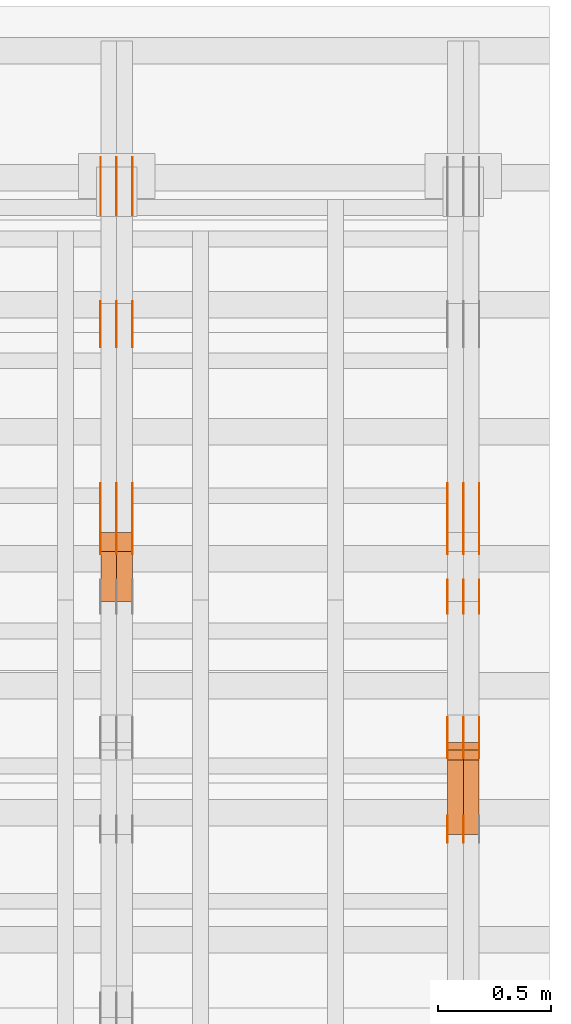
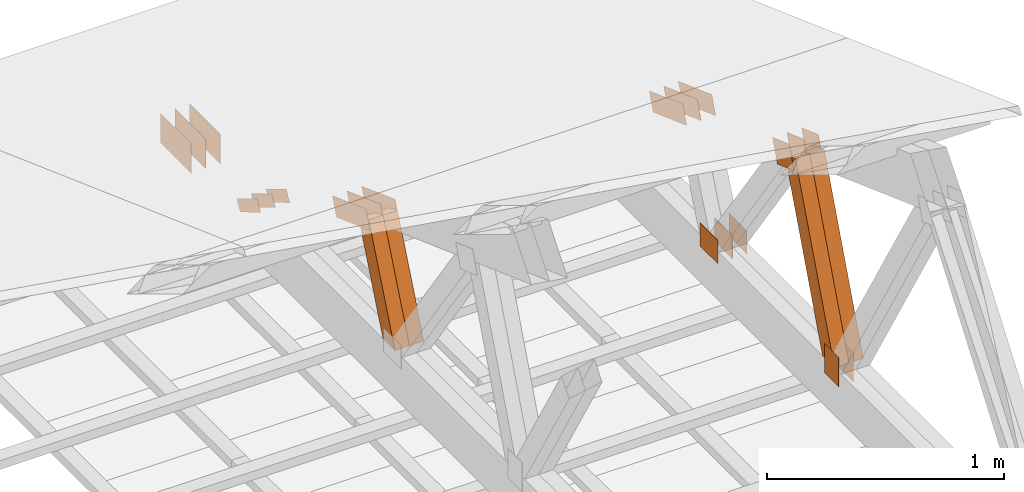
# One storey, part 177 of 189: 30 proxies.
"""IFC2X3 building model written with IfcOpenShell, lengths in millimetres."""

from ifc_helpers import new_model, entity, si_unit, converted_unit, derived_unit, direction, frame, frame_2d, origin, origin_2d_with_axis, place, context, subcontext, project, spatial, polyline, rectangle, outline, extrude, source, transform, mapped, material, type_object, type_shapes, element, save


model = new_model("IFC2X3")

# Units and contexts
model_context = context("Model", 3, precision=0.01, world=origin(), true_north=direction((6.12303176911189e-17, 1.0)))
body_context = subcontext(model_context, "Body", "Model", "MODEL_VIEW")
ifc_project = project(units=[si_unit("LENGTHUNIT", "METRE", prefix="MILLI"), si_unit("AREAUNIT", "SQUARE_METRE"), si_unit("VOLUMEUNIT", "CUBIC_METRE"), converted_unit("PLANEANGLEUNIT", "DEGREE", entity("IfcRatioMeasure", 0.0174532925199433), si_unit("PLANEANGLEUNIT", "RADIAN"), dimensions=[0, 0, 0, 0, 0, 0, 0]), si_unit("MASSUNIT", "GRAM", prefix="KILO"), derived_unit("MASSDENSITYUNIT", [(si_unit("MASSUNIT", "GRAM", prefix="KILO"), 1), (si_unit("LENGTHUNIT", "METRE"), -3)]), si_unit("TIMEUNIT", "SECOND"), si_unit("FREQUENCYUNIT", "HERTZ"), si_unit("THERMODYNAMICTEMPERATUREUNIT", "DEGREE_CELSIUS"), derived_unit("THERMALTRANSMITTANCEUNIT", [(si_unit("MASSUNIT", "GRAM", prefix="KILO"), 1), (si_unit("THERMODYNAMICTEMPERATUREUNIT", "KELVIN"), -1), (si_unit("TIMEUNIT", "SECOND"), -3)]), derived_unit("VOLUMETRICFLOWRATEUNIT", [(si_unit("LENGTHUNIT", "METRE"), 3), (si_unit("TIMEUNIT", "SECOND"), -1)]), si_unit("ELECTRICCURRENTUNIT", "AMPERE"), si_unit("ELECTRICVOLTAGEUNIT", "VOLT"), si_unit("POWERUNIT", "WATT"), si_unit("FORCEUNIT", "NEWTON"), si_unit("ILLUMINANCEUNIT", "LUX"), si_unit("LUMINOUSFLUXUNIT", "LUMEN"), si_unit("LUMINOUSINTENSITYUNIT", "CANDELA"), derived_unit("USERDEFINED", [(si_unit("MASSUNIT", "GRAM", prefix="KILO"), -1), (si_unit("LENGTHUNIT", "METRE"), -2), (si_unit("TIMEUNIT", "SECOND"), 3), (si_unit("LUMINOUSFLUXUNIT", "LUMEN"), 1)]), derived_unit("LINEARVELOCITYUNIT", [(si_unit("LENGTHUNIT", "METRE"), 1), (si_unit("TIMEUNIT", "SECOND"), -1)]), si_unit("PRESSUREUNIT", "PASCAL"), derived_unit("USERDEFINED", [(si_unit("LENGTHUNIT", "METRE"), -2), (si_unit("MASSUNIT", "GRAM", prefix="KILO"), 1), (si_unit("TIMEUNIT", "SECOND"), -2)])], contexts=[model_context])

# Site, building, storey
site_placement = place(None, origin())
site = spatial("IfcSite", under=ifc_project, at=site_placement, CompositionType="ELEMENT")
building_placement = place(site_placement, origin())
building = spatial("IfcBuilding", under=site, at=building_placement, CompositionType="ELEMENT")
storey_placement = place(building_placement, origin())
storey = spatial("IfcBuildingStorey", under=building, at=storey_placement, Name="Default", CompositionType="ELEMENT", Elevation=0.0)

# Proxies
ifc_material_1 = material(Name="IfcSurfaceStyle #278914")
building_element_proxy_type_1 = type_object("IfcBuildingElementProxyType", PredefinedType="NOTDEFINED", material=ifc_material_1)
shared_shape_1 = source(origin(), body_context, "Body", "SweptSolid", [
    extrude(rectangle(XDim=150.0, YDim=120.0, at=frame_2d((-7.105427357601e-15, 0.0), x_axis=(1.0, 0.0))), frame((75.0, 60.0, 0.0), z_axis=(0.0, 0.0, 1.0), x_axis=(-1.0, 0.0, 0.0)), (0.0, 0.0, 1.0), 1.29999999999999),
])
type_shapes(building_element_proxy_type_1, [shared_shape_1])
proxy_1_placement = place(building_placement, frame((49771.3, 26439.0083007813, 170.0), z_axis=(-1.0, 0.0, 0.0), x_axis=(0.0, 0.0, 1.0)))
element("IfcBuildingElementProxy", 1, at=proxy_1_placement, inside=storey, type_object=building_element_proxy_type_1, material=ifc_material_1, context=body_context, shape_type="MappedRepresentation", body=[
    mapped(shared_shape_1, transform((0.0, 0.0, 0.0), scale=1.0)),
])
ifc_material_2 = material(Name="IfcSurfaceStyle #278857")
building_element_proxy_type_2 = type_object("IfcBuildingElementProxyType", PredefinedType="NOTDEFINED", material=ifc_material_2)
shared_shape_2 = source(origin(), body_context, "Body", "SweptSolid", [
    extrude(rectangle(XDim=150.0, YDim=120.0, at=frame_2d((-7.105427357601e-15, 0.0), x_axis=(1.0, 0.0))), frame((75.0, 60.0, 0.0), z_axis=(0.0, 0.0, 1.0), x_axis=(-1.0, 0.0, 0.0)), (0.0, 0.0, 1.0), 1.29999999999999),
])
type_shapes(building_element_proxy_type_2, [shared_shape_2])
proxy_2_placement = place(building_placement, frame((49700.0, 26439.0083007813, 170.0), z_axis=(-1.0, 0.0, 0.0), x_axis=(0.0, 0.0, 1.0)))
element("IfcBuildingElementProxy", 2, at=proxy_2_placement, inside=storey, type_object=building_element_proxy_type_2, material=ifc_material_2, context=body_context, shape_type="MappedRepresentation", body=[
    mapped(shared_shape_2, transform((0.0, 0.0, 0.0), scale=1.0)),
])
ifc_material_3 = material(Name="IfcSurfaceStyle #278344")
building_element_proxy_type_3 = type_object("IfcBuildingElementProxyType", PredefinedType="NOTDEFINED", material=ifc_material_3)
shared_shape_3 = source(origin(), body_context, "Body", "SweptSolid", [
    extrude(outline(polyline([(-74.9999684051023, -60.0), (75.0000251009964, -60.0), (74.9999475298495, 60.0), (-75.0000042257435, 60.0), (-74.9999684051023, -60.0)])), frame((75.0000251009964, 60.0000006265238, 0.0), z_axis=(0.0, 0.0, 1.0), x_axis=(-1.0, 0.0, 0.0)), (0.0, 0.0, 1.0), 1.3),
])
type_shapes(building_element_proxy_type_3, [shared_shape_3])
proxy_3_placement = place(building_placement, frame((49841.3, 26956.490053282, 1001.18769055967), z_axis=(-1.0, 0.0, 0.0), x_axis=(0.0, -0.939692620785908, 0.342020143325669)))
element("IfcBuildingElementProxy", 3, at=proxy_3_placement, inside=storey, type_object=building_element_proxy_type_3, material=ifc_material_3, context=body_context, shape_type="MappedRepresentation", body=[
    mapped(shared_shape_3, transform((0.0, 0.0, 0.0), scale=1.0)),
])
ifc_material_4 = material(Name="IfcSurfaceStyle #278287")
building_element_proxy_type_4 = type_object("IfcBuildingElementProxyType", PredefinedType="NOTDEFINED", material=ifc_material_4)
shared_shape_4 = source(origin(), body_context, "Body", "SweptSolid", [
    extrude(outline(polyline([(-74.9999684051023, -60.0), (75.0000251009964, -60.0), (74.9999475298495, 60.0), (-75.0000042257435, 60.0), (-74.9999684051023, -60.0)])), frame((75.0000251009964, 60.0000006265238, 0.0), z_axis=(0.0, 0.0, 1.0), x_axis=(-1.0, 0.0, 0.0)), (0.0, 0.0, 1.0), 1.29999999999999),
])
type_shapes(building_element_proxy_type_4, [shared_shape_4])
proxy_4_placement = place(building_placement, frame((49770.0, 26956.490053282, 1001.18769055967), z_axis=(-1.0, 0.0, 0.0), x_axis=(0.0, -0.939692620785908, 0.342020143325669)))
element("IfcBuildingElementProxy", 4, at=proxy_4_placement, inside=storey, type_object=building_element_proxy_type_4, material=ifc_material_4, context=body_context, shape_type="MappedRepresentation", body=[
    mapped(shared_shape_4, transform((0.0, 0.0, 0.0), scale=1.0)),
])
ifc_material_5 = material(Name="IfcSurfaceStyle #278230")
building_element_proxy_type_5 = type_object("IfcBuildingElementProxyType", PredefinedType="NOTDEFINED", material=ifc_material_5)
shared_shape_5 = source(origin(), body_context, "Body", "SweptSolid", [
    extrude(outline(polyline([(-74.9999684051023, -60.0), (75.0000251009964, -60.0), (74.9999475298495, 60.0), (-75.0000042257435, 60.0), (-74.9999684051023, -60.0)])), frame((75.0000251009964, 60.0000006265238, 0.0), z_axis=(0.0, 0.0, 1.0), x_axis=(-1.0, 0.0, 0.0)), (0.0, 0.0, 1.0), 1.29999999999999),
])
type_shapes(building_element_proxy_type_5, [shared_shape_5])
proxy_5_placement = place(building_placement, frame((49771.3, 26956.490053282, 1001.18769055967), z_axis=(-1.0, 0.0, 0.0), x_axis=(0.0, -0.939692620785908, 0.342020143325669)))
element("IfcBuildingElementProxy", 5, at=proxy_5_placement, inside=storey, type_object=building_element_proxy_type_5, material=ifc_material_5, context=body_context, shape_type="MappedRepresentation", body=[
    mapped(shared_shape_5, transform((0.0, 0.0, 0.0), scale=1.0)),
])
ifc_material_6 = material(Name="IfcSurfaceStyle #278173")
building_element_proxy_type_6 = type_object("IfcBuildingElementProxyType", PredefinedType="NOTDEFINED", material=ifc_material_6)
shared_shape_6 = source(origin(), body_context, "Body", "SweptSolid", [
    extrude(outline(polyline([(-74.9999684051023, -60.0), (75.0000251009964, -60.0), (74.9999475298495, 60.0), (-75.0000042257435, 60.0), (-74.9999684051023, -60.0)])), frame((75.0000251009964, 60.0000006265238, 0.0), z_axis=(0.0, 0.0, 1.0), x_axis=(-1.0, 0.0, 0.0)), (0.0, 0.0, 1.0), 1.29999999999999),
])
type_shapes(building_element_proxy_type_6, [shared_shape_6])
proxy_6_placement = place(building_placement, frame((49700.0, 26956.490053282, 1001.18769055967), z_axis=(-1.0, 0.0, 0.0), x_axis=(0.0, -0.939692620785908, 0.342020143325669)))
element("IfcBuildingElementProxy", 6, at=proxy_6_placement, inside=storey, type_object=building_element_proxy_type_6, material=ifc_material_6, context=body_context, shape_type="MappedRepresentation", body=[
    mapped(shared_shape_6, transform((0.0, 0.0, 0.0), scale=1.0)),
])
ifc_material_7 = material(Name="IfcSurfaceStyle #278116")
building_element_proxy_type_7 = type_object("IfcBuildingElementProxyType", PredefinedType="NOTDEFINED", material=ifc_material_7)
shared_shape_7 = source(origin(), body_context, "Body", "SweptSolid", [
    extrude(rectangle(XDim=150.0, YDim=120.0, at=origin_2d_with_axis()), frame((75.0, 60.0, 0.0), z_axis=(0.0, 0.0, 1.0), x_axis=(-1.0, 0.0, 0.0)), (0.0, 0.0, 1.0), 1.3),
])
type_shapes(building_element_proxy_type_7, [shared_shape_7])
proxy_7_placement = place(building_placement, frame((49841.3, 27607.3129882813, 185.0), z_axis=(-1.0, 0.0, 0.0), x_axis=(0.0, -1.0, 0.0)))
element("IfcBuildingElementProxy", 7, at=proxy_7_placement, inside=storey, type_object=building_element_proxy_type_7, material=ifc_material_7, context=body_context, shape_type="MappedRepresentation", body=[
    mapped(shared_shape_7, transform((0.0, 0.0, 0.0), scale=1.0)),
])
ifc_material_8 = material(Name="IfcSurfaceStyle #278059")
building_element_proxy_type_8 = type_object("IfcBuildingElementProxyType", PredefinedType="NOTDEFINED", material=ifc_material_8)
shared_shape_8 = source(origin(), body_context, "Body", "SweptSolid", [
    extrude(rectangle(XDim=150.0, YDim=120.0, at=origin_2d_with_axis()), frame((75.0, 60.0, 0.0), z_axis=(0.0, 0.0, 1.0), x_axis=(-1.0, 0.0, 0.0)), (0.0, 0.0, 1.0), 1.29999999999999),
])
type_shapes(building_element_proxy_type_8, [shared_shape_8])
proxy_8_placement = place(building_placement, frame((49770.0, 27607.3129882813, 185.0), z_axis=(-1.0, 0.0, 0.0), x_axis=(0.0, -1.0, 0.0)))
element("IfcBuildingElementProxy", 8, at=proxy_8_placement, inside=storey, type_object=building_element_proxy_type_8, material=ifc_material_8, context=body_context, shape_type="MappedRepresentation", body=[
    mapped(shared_shape_8, transform((0.0, 0.0, 0.0), scale=1.0)),
])
ifc_material_9 = material(Name="IfcSurfaceStyle #278002")
building_element_proxy_type_9 = type_object("IfcBuildingElementProxyType", PredefinedType="NOTDEFINED", material=ifc_material_9)
shared_shape_9 = source(origin(), body_context, "Body", "SweptSolid", [
    extrude(rectangle(XDim=150.0, YDim=120.0, at=origin_2d_with_axis()), frame((75.0, 60.0, 0.0), z_axis=(0.0, 0.0, 1.0), x_axis=(-1.0, 0.0, 0.0)), (0.0, 0.0, 1.0), 1.29999999999999),
])
type_shapes(building_element_proxy_type_9, [shared_shape_9])
proxy_9_placement = place(building_placement, frame((49771.3, 27607.3129882813, 185.0), z_axis=(-1.0, 0.0, 0.0), x_axis=(0.0, -1.0, 0.0)))
element("IfcBuildingElementProxy", 9, at=proxy_9_placement, inside=storey, type_object=building_element_proxy_type_9, material=ifc_material_9, context=body_context, shape_type="MappedRepresentation", body=[
    mapped(shared_shape_9, transform((0.0, 0.0, 0.0), scale=1.0)),
])
ifc_material_10 = material(Name="IfcSurfaceStyle #277945")
building_element_proxy_type_10 = type_object("IfcBuildingElementProxyType", PredefinedType="NOTDEFINED", material=ifc_material_10)
shared_shape_10 = source(origin(), body_context, "Body", "SweptSolid", [
    extrude(rectangle(XDim=150.0, YDim=120.0, at=origin_2d_with_axis()), frame((75.0, 60.0, 0.0), z_axis=(0.0, 0.0, 1.0), x_axis=(-1.0, 0.0, 0.0)), (0.0, 0.0, 1.0), 1.29999999999999),
])
type_shapes(building_element_proxy_type_10, [shared_shape_10])
proxy_10_placement = place(building_placement, frame((49700.0, 27607.3129882813, 185.0), z_axis=(-1.0, 0.0, 0.0), x_axis=(0.0, -1.0, 0.0)))
element("IfcBuildingElementProxy", 10, at=proxy_10_placement, inside=storey, type_object=building_element_proxy_type_10, material=ifc_material_10, context=body_context, shape_type="MappedRepresentation", body=[
    mapped(shared_shape_10, transform((0.0, 0.0, 0.0), scale=1.0)),
])
ifc_material_11 = material(Name="IfcSurfaceStyle #277432")
building_element_proxy_type_11 = type_object("IfcBuildingElementProxyType", PredefinedType="NOTDEFINED", material=ifc_material_11)
shared_shape_11 = source(origin(), body_context, "Body", "SweptSolid", [
    extrude(outline(polyline([(-150.000004175486, -48.0000091256405), (150.000055794777, -48.0000091256405), (149.99999373786, 48.0000091256405), (-150.000045357151, 48.0000091256405), (-150.000004175486, -48.0000091256405)])), frame((150.000055794777, 48.0000091256405, 0.0), z_axis=(0.0, 0.0, 1.0), x_axis=(-1.0, 0.0, 0.0)), (0.0, 0.0, 1.0), 1.29999999999999),
])
type_shapes(building_element_proxy_type_11, [shared_shape_11])
proxy_11_placement = place(building_placement, frame((49841.3, 28002.7008500375, 633.16821439849), z_axis=(-1.0, 0.0, 0.0), x_axis=(0.0, -0.939692620785908, 0.342020143325669)))
element("IfcBuildingElementProxy", 11, at=proxy_11_placement, inside=storey, type_object=building_element_proxy_type_11, material=ifc_material_11, context=body_context, shape_type="MappedRepresentation", body=[
    mapped(shared_shape_11, transform((0.0, 0.0, 0.0), scale=1.0)),
])
ifc_material_12 = material(Name="IfcSurfaceStyle #277375")
building_element_proxy_type_12 = type_object("IfcBuildingElementProxyType", PredefinedType="NOTDEFINED", material=ifc_material_12)
shared_shape_12 = source(origin(), body_context, "Body", "SweptSolid", [
    extrude(outline(polyline([(-150.000004175486, -48.0000091256405), (150.000055794777, -48.0000091256405), (149.99999373786, 48.0000091256405), (-150.000045357151, 48.0000091256405), (-150.000004175486, -48.0000091256405)])), frame((150.000055794777, 48.0000091256405, 0.0), z_axis=(0.0, 0.0, 1.0), x_axis=(-1.0, 0.0, 0.0)), (0.0, 0.0, 1.0), 1.29999999999998),
])
type_shapes(building_element_proxy_type_12, [shared_shape_12])
proxy_12_placement = place(building_placement, frame((49770.0, 28002.7008500375, 633.16821439849), z_axis=(-1.0, 0.0, 0.0), x_axis=(0.0, -0.939692620785908, 0.342020143325669)))
element("IfcBuildingElementProxy", 12, at=proxy_12_placement, inside=storey, type_object=building_element_proxy_type_12, material=ifc_material_12, context=body_context, shape_type="MappedRepresentation", body=[
    mapped(shared_shape_12, transform((0.0, 0.0, 0.0), scale=1.0)),
])
ifc_material_13 = material(Name="IfcSurfaceStyle #277318")
building_element_proxy_type_13 = type_object("IfcBuildingElementProxyType", PredefinedType="NOTDEFINED", material=ifc_material_13)
shared_shape_13 = source(origin(), body_context, "Body", "SweptSolid", [
    extrude(outline(polyline([(-150.000004175486, -48.0000091256405), (150.000055794777, -48.0000091256405), (149.99999373786, 48.0000091256405), (-150.000045357151, 48.0000091256405), (-150.000004175486, -48.0000091256405)])), frame((150.000055794777, 48.0000091256405, 0.0), z_axis=(0.0, 0.0, 1.0), x_axis=(-1.0, 0.0, 0.0)), (0.0, 0.0, 1.0), 1.29999999999998),
])
type_shapes(building_element_proxy_type_13, [shared_shape_13])
proxy_13_placement = place(building_placement, frame((49771.3, 28002.7008500375, 633.16821439849), z_axis=(-1.0, 0.0, 0.0), x_axis=(0.0, -0.939692620785908, 0.342020143325669)))
element("IfcBuildingElementProxy", 13, at=proxy_13_placement, inside=storey, type_object=building_element_proxy_type_13, material=ifc_material_13, context=body_context, shape_type="MappedRepresentation", body=[
    mapped(shared_shape_13, transform((0.0, 0.0, 0.0), scale=1.0)),
])
ifc_material_14 = material(Name="IfcSurfaceStyle #277261")
building_element_proxy_type_14 = type_object("IfcBuildingElementProxyType", PredefinedType="NOTDEFINED", material=ifc_material_14)
shared_shape_14 = source(origin(), body_context, "Body", "SweptSolid", [
    extrude(outline(polyline([(-150.000004175486, -48.0000091256405), (150.000055794777, -48.0000091256405), (149.99999373786, 48.0000091256405), (-150.000045357151, 48.0000091256405), (-150.000004175486, -48.0000091256405)])), frame((150.000055794777, 48.0000091256405, 0.0), z_axis=(0.0, 0.0, 1.0), x_axis=(-1.0, 0.0, 0.0)), (0.0, 0.0, 1.0), 1.29999999999998),
])
type_shapes(building_element_proxy_type_14, [shared_shape_14])
proxy_14_placement = place(building_placement, frame((49700.0, 28002.7008500375, 633.16821439849), z_axis=(-1.0, 0.0, 0.0), x_axis=(0.0, -0.939692620785908, 0.342020143325669)))
element("IfcBuildingElementProxy", 14, at=proxy_14_placement, inside=storey, type_object=building_element_proxy_type_14, material=ifc_material_14, context=body_context, shape_type="MappedRepresentation", body=[
    mapped(shared_shape_14, transform((0.0, 0.0, 0.0), scale=1.0)),
])
ifc_material_15 = material(Name="IfcSurfaceStyle #270868")
building_element_proxy_type_15 = type_object("IfcBuildingElementProxyType", Name="T1-W14 270866", PredefinedType="NOTDEFINED", material=ifc_material_15)
shared_shape_15 = source(origin(), body_context, "Body", "SweptSolid", [
    extrude(outline(polyline([(-561.981237417233, -47.499947472121), (373.092610496013, -47.499947472121), (373.679602940405, -4.61719047935016e-05), (341.277449358876, 47.4999705580734), (-526.068425378061, 47.4999705580734), (-561.981237417233, -47.499947472121)])), frame((373.679632439416, 47.500120814091, 0.0), z_axis=(0.0, 0.0, 1.0), x_axis=(-1.0, 0.0, 0.0)), (0.0, 0.0, 1.0), 69.9999999999999),
])
type_shapes(building_element_proxy_type_15, [shared_shape_15])
proxy_15_placement = place(building_placement, frame((49840.0, 26895.4809555667, 1086.61918844835), z_axis=(-1.0, 0.0, 0.0), x_axis=(0.0, -0.353606472447933, -0.935394281916951)))
element("IfcBuildingElementProxy", 15, at=proxy_15_placement, inside=storey, type_object=building_element_proxy_type_15, material=ifc_material_15, Name="T1-W14", context=body_context, shape_type="MappedRepresentation", body=[
    mapped(shared_shape_15, transform((0.0, 0.0, 0.0), scale=1.0)),
])
ifc_material_16 = material(Name="IfcSurfaceStyle #270802")
building_element_proxy_type_16 = type_object("IfcBuildingElementProxyType", Name="T1-W14 270800", PredefinedType="NOTDEFINED", material=ifc_material_16)
shared_shape_16 = source(origin(), body_context, "Body", "SweptSolid", [
    extrude(outline(polyline([(-561.981237417233, -47.499947472121), (373.092610496013, -47.499947472121), (373.679602940405, -4.61719047935016e-05), (341.277449358876, 47.4999705580734), (-526.068425378061, 47.4999705580734), (-561.981237417233, -47.499947472121)])), frame((373.679632439416, 47.500120814091, 0.0), z_axis=(0.0, 0.0, 1.0), x_axis=(-1.0, 0.0, 0.0)), (0.0, 0.0, 1.0), 69.9999999999999),
])
type_shapes(building_element_proxy_type_16, [shared_shape_16])
proxy_16_placement = place(building_placement, frame((49770.0, 26895.4809555667, 1086.61918844835), z_axis=(-1.0, 0.0, 0.0), x_axis=(0.0, -0.353606472447933, -0.935394281916951)))
element("IfcBuildingElementProxy", 16, at=proxy_16_placement, inside=storey, type_object=building_element_proxy_type_16, material=ifc_material_16, Name="T1-W14", context=body_context, shape_type="MappedRepresentation", body=[
    mapped(shared_shape_16, transform((0.0, 0.0, 0.0), scale=1.0)),
])
ifc_material_17 = material(Name="IfcSurfaceStyle #261642")
building_element_proxy_type_17 = type_object("IfcBuildingElementProxyType", PredefinedType="NOTDEFINED", material=ifc_material_17)
shared_shape_17 = source(origin(), body_context, "Body", "SweptSolid", [
    extrude(outline(polyline([(-150.000004175486, -48.0000091256405), (150.000055794777, -48.0000091256405), (149.99999373786, 48.0000091256405), (-150.000045357151, 48.0000091256405), (-150.000004175486, -48.0000091256405)])), frame((150.000055794777, 48.0000091256405, 0.0), z_axis=(0.0, 0.0, 1.0), x_axis=(-1.0, 0.0, 0.0)), (0.0, 0.0, 1.0), 1.29999999999999),
])
type_shapes(building_element_proxy_type_17, [shared_shape_17])
proxy_17_placement = place(building_placement, frame((48301.3, 28002.7008500375, 633.16821439849), z_axis=(-1.0, 0.0, 0.0), x_axis=(0.0, -0.939692620785908, 0.342020143325669)))
element("IfcBuildingElementProxy", 17, at=proxy_17_placement, inside=storey, type_object=building_element_proxy_type_17, material=ifc_material_17, context=body_context, shape_type="MappedRepresentation", body=[
    mapped(shared_shape_17, transform((0.0, 0.0, 0.0), scale=1.0)),
])
ifc_material_18 = material(Name="IfcSurfaceStyle #261585")
building_element_proxy_type_18 = type_object("IfcBuildingElementProxyType", PredefinedType="NOTDEFINED", material=ifc_material_18)
shared_shape_18 = source(origin(), body_context, "Body", "SweptSolid", [
    extrude(outline(polyline([(-150.000004175486, -48.0000091256405), (150.000055794777, -48.0000091256405), (149.99999373786, 48.0000091256405), (-150.000045357151, 48.0000091256405), (-150.000004175486, -48.0000091256405)])), frame((150.000055794777, 48.0000091256405, 0.0), z_axis=(0.0, 0.0, 1.0), x_axis=(-1.0, 0.0, 0.0)), (0.0, 0.0, 1.0), 1.29999999999998),
])
type_shapes(building_element_proxy_type_18, [shared_shape_18])
proxy_18_placement = place(building_placement, frame((48230.0, 28002.7008500375, 633.16821439849), z_axis=(-1.0, 0.0, 0.0), x_axis=(0.0, -0.939692620785908, 0.342020143325669)))
element("IfcBuildingElementProxy", 18, at=proxy_18_placement, inside=storey, type_object=building_element_proxy_type_18, material=ifc_material_18, context=body_context, shape_type="MappedRepresentation", body=[
    mapped(shared_shape_18, transform((0.0, 0.0, 0.0), scale=1.0)),
])
ifc_material_19 = material(Name="IfcSurfaceStyle #261528")
building_element_proxy_type_19 = type_object("IfcBuildingElementProxyType", PredefinedType="NOTDEFINED", material=ifc_material_19)
shared_shape_19 = source(origin(), body_context, "Body", "SweptSolid", [
    extrude(outline(polyline([(-150.000004175486, -48.0000091256405), (150.000055794777, -48.0000091256405), (149.99999373786, 48.0000091256405), (-150.000045357151, 48.0000091256405), (-150.000004175486, -48.0000091256405)])), frame((150.000055794777, 48.0000091256405, 0.0), z_axis=(0.0, 0.0, 1.0), x_axis=(-1.0, 0.0, 0.0)), (0.0, 0.0, 1.0), 1.29999999999998),
])
type_shapes(building_element_proxy_type_19, [shared_shape_19])
proxy_19_placement = place(building_placement, frame((48231.3, 28002.7008500375, 633.16821439849), z_axis=(-1.0, 0.0, 0.0), x_axis=(0.0, -0.939692620785908, 0.342020143325669)))
element("IfcBuildingElementProxy", 19, at=proxy_19_placement, inside=storey, type_object=building_element_proxy_type_19, material=ifc_material_19, context=body_context, shape_type="MappedRepresentation", body=[
    mapped(shared_shape_19, transform((0.0, 0.0, 0.0), scale=1.0)),
])
ifc_material_20 = material(Name="IfcSurfaceStyle #261471")
building_element_proxy_type_20 = type_object("IfcBuildingElementProxyType", PredefinedType="NOTDEFINED", material=ifc_material_20)
shared_shape_20 = source(origin(), body_context, "Body", "SweptSolid", [
    extrude(outline(polyline([(-150.000004175486, -48.0000091256405), (150.000055794777, -48.0000091256405), (149.99999373786, 48.0000091256405), (-150.000045357151, 48.0000091256405), (-150.000004175486, -48.0000091256405)])), frame((150.000055794777, 48.0000091256405, 0.0), z_axis=(0.0, 0.0, 1.0), x_axis=(-1.0, 0.0, 0.0)), (0.0, 0.0, 1.0), 1.29999999999998),
])
type_shapes(building_element_proxy_type_20, [shared_shape_20])
proxy_20_placement = place(building_placement, frame((48160.0, 28002.7008500375, 633.16821439849), z_axis=(-1.0, 0.0, 0.0), x_axis=(0.0, -0.939692620785908, 0.342020143325669)))
element("IfcBuildingElementProxy", 20, at=proxy_20_placement, inside=storey, type_object=building_element_proxy_type_20, material=ifc_material_20, context=body_context, shape_type="MappedRepresentation", body=[
    mapped(shared_shape_20, transform((0.0, 0.0, 0.0), scale=1.0)),
])
ifc_material_21 = material(Name="IfcSurfaceStyle #261414")
building_element_proxy_type_21 = type_object("IfcBuildingElementProxyType", PredefinedType="NOTDEFINED", material=ifc_material_21)
shared_shape_21 = source(origin(), body_context, "Body", "SweptSolid", [
    extrude(outline(polyline([(-100.000014621824, -30.0000173081658), (100.000025679578, -30.0000173081658), (100.000010707989, 30.0000173081658), (-100.000021765743, 30.0000173081658), (-100.000014621824, -30.0000173081658)])), frame((100.000025679578, 30.0000173081658, 0.0), z_axis=(0.0, 0.0, 1.0), x_axis=(-1.0, 0.0, 0.0)), (0.0, 0.0, 1.0), 1.3),
])
type_shapes(building_element_proxy_type_21, [shared_shape_21])
proxy_21_placement = place(building_placement, frame((48301.3, 28812.2744732883, 167.948789809131), z_axis=(-1.0, 0.0, 0.0), x_axis=(0.0, -0.858392121304013, 0.51299411895576)))
element("IfcBuildingElementProxy", 21, at=proxy_21_placement, inside=storey, type_object=building_element_proxy_type_21, material=ifc_material_21, context=body_context, shape_type="MappedRepresentation", body=[
    mapped(shared_shape_21, transform((0.0, 0.0, 0.0), scale=1.0)),
])
ifc_material_22 = material(Name="IfcSurfaceStyle #261357")
building_element_proxy_type_22 = type_object("IfcBuildingElementProxyType", PredefinedType="NOTDEFINED", material=ifc_material_22)
shared_shape_22 = source(origin(), body_context, "Body", "SweptSolid", [
    extrude(outline(polyline([(-100.000014621824, -30.0000173081658), (100.000025679578, -30.0000173081658), (100.000010707989, 30.0000173081658), (-100.000021765743, 30.0000173081658), (-100.000014621824, -30.0000173081658)])), frame((100.000025679578, 30.0000173081658, 0.0), z_axis=(0.0, 0.0, 1.0), x_axis=(-1.0, 0.0, 0.0)), (0.0, 0.0, 1.0), 1.29999999999998),
])
type_shapes(building_element_proxy_type_22, [shared_shape_22])
proxy_22_placement = place(building_placement, frame((48230.0, 28812.2744732883, 167.948789809131), z_axis=(-1.0, 0.0, 0.0), x_axis=(0.0, -0.858392121304013, 0.51299411895576)))
element("IfcBuildingElementProxy", 22, at=proxy_22_placement, inside=storey, type_object=building_element_proxy_type_22, material=ifc_material_22, context=body_context, shape_type="MappedRepresentation", body=[
    mapped(shared_shape_22, transform((0.0, 0.0, 0.0), scale=1.0)),
])
ifc_material_23 = material(Name="IfcSurfaceStyle #261300")
building_element_proxy_type_23 = type_object("IfcBuildingElementProxyType", PredefinedType="NOTDEFINED", material=ifc_material_23)
shared_shape_23 = source(origin(), body_context, "Body", "SweptSolid", [
    extrude(outline(polyline([(-100.000014621824, -30.0000173081658), (100.000025679578, -30.0000173081658), (100.000010707989, 30.0000173081658), (-100.000021765743, 30.0000173081658), (-100.000014621824, -30.0000173081658)])), frame((100.000025679578, 30.0000173081658, 0.0), z_axis=(0.0, 0.0, 1.0), x_axis=(-1.0, 0.0, 0.0)), (0.0, 0.0, 1.0), 1.29999999999998),
])
type_shapes(building_element_proxy_type_23, [shared_shape_23])
proxy_23_placement = place(building_placement, frame((48231.3, 28812.2744732883, 167.948789809131), z_axis=(-1.0, 0.0, 0.0), x_axis=(0.0, -0.858392121304013, 0.51299411895576)))
element("IfcBuildingElementProxy", 23, at=proxy_23_placement, inside=storey, type_object=building_element_proxy_type_23, material=ifc_material_23, context=body_context, shape_type="MappedRepresentation", body=[
    mapped(shared_shape_23, transform((0.0, 0.0, 0.0), scale=1.0)),
])
ifc_material_24 = material(Name="IfcSurfaceStyle #261243")
building_element_proxy_type_24 = type_object("IfcBuildingElementProxyType", PredefinedType="NOTDEFINED", material=ifc_material_24)
shared_shape_24 = source(origin(), body_context, "Body", "SweptSolid", [
    extrude(outline(polyline([(-100.000014621824, -30.0000173081658), (100.000025679578, -30.0000173081658), (100.000010707989, 30.0000173081658), (-100.000021765743, 30.0000173081658), (-100.000014621824, -30.0000173081658)])), frame((100.000025679578, 30.0000173081658, 0.0), z_axis=(0.0, 0.0, 1.0), x_axis=(-1.0, 0.0, 0.0)), (0.0, 0.0, 1.0), 1.29999999999999),
])
type_shapes(building_element_proxy_type_24, [shared_shape_24])
proxy_24_placement = place(building_placement, frame((48160.0, 28812.2744732883, 167.948789809131), z_axis=(-1.0, 0.0, 0.0), x_axis=(0.0, -0.858392121304013, 0.51299411895576)))
element("IfcBuildingElementProxy", 24, at=proxy_24_placement, inside=storey, type_object=building_element_proxy_type_24, material=ifc_material_24, context=body_context, shape_type="MappedRepresentation", body=[
    mapped(shared_shape_24, transform((0.0, 0.0, 0.0), scale=1.0)),
])
ifc_material_25 = material(Name="IfcSurfaceStyle #260958")
building_element_proxy_type_25 = type_object("IfcBuildingElementProxyType", PredefinedType="NOTDEFINED", material=ifc_material_25)
shared_shape_25 = source(origin(), body_context, "Body", "SweptSolid", [
    extrude(rectangle(XDim=258.000001907349, YDim=151.999992370605, at=origin_2d_with_axis()), frame((129.000001782157, 75.9999961853027, 0.0), z_axis=(0.0, 0.0, 1.0), x_axis=(-1.0, 0.0, 0.0)), (0.0, 0.0, 1.0), 0.999999999999984),
])
type_shapes(building_element_proxy_type_25, [shared_shape_25])
proxy_25_placement = place(building_placement, frame((48301.0, 29483.7634609878, 116.138221740723), z_axis=(-1.0, 0.0, 0.0), x_axis=(0.0, -1.0, 0.0)))
element("IfcBuildingElementProxy", 25, at=proxy_25_placement, inside=storey, type_object=building_element_proxy_type_25, material=ifc_material_25, Name="GNT100S 152x258", context=body_context, shape_type="MappedRepresentation", body=[
    mapped(shared_shape_25, transform((0.0, 0.0, 0.0), scale=1.0)),
])
ifc_material_26 = material(Name="IfcSurfaceStyle #260901")
building_element_proxy_type_26 = type_object("IfcBuildingElementProxyType", PredefinedType="NOTDEFINED", material=ifc_material_26)
shared_shape_26 = source(origin(), body_context, "Body", "SweptSolid", [
    extrude(rectangle(XDim=258.000001907349, YDim=151.999992370605, at=origin_2d_with_axis()), frame((129.000001782157, 75.9999961853027, 0.0), z_axis=(0.0, 0.0, 1.0), x_axis=(-1.0, 0.0, 0.0)), (0.0, 0.0, 1.0), 0.999999999999984),
])
type_shapes(building_element_proxy_type_26, [shared_shape_26])
proxy_26_placement = place(building_placement, frame((48230.0, 29483.7634609878, 116.138221740723), z_axis=(-1.0, 0.0, 0.0), x_axis=(0.0, -1.0, 0.0)))
element("IfcBuildingElementProxy", 26, at=proxy_26_placement, inside=storey, type_object=building_element_proxy_type_26, material=ifc_material_26, Name="GNT100S 152x258", context=body_context, shape_type="MappedRepresentation", body=[
    mapped(shared_shape_26, transform((0.0, 0.0, 0.0), scale=1.0)),
])
ifc_material_27 = material(Name="IfcSurfaceStyle #260844")
building_element_proxy_type_27 = type_object("IfcBuildingElementProxyType", PredefinedType="NOTDEFINED", material=ifc_material_27)
shared_shape_27 = source(origin(), body_context, "Body", "SweptSolid", [
    extrude(rectangle(XDim=258.000001907349, YDim=151.999992370605, at=origin_2d_with_axis()), frame((129.000001782157, 75.9999961853027, 0.0), z_axis=(0.0, 0.0, 1.0), x_axis=(-1.0, 0.0, 0.0)), (0.0, 0.0, 1.0), 0.999999999999984),
])
type_shapes(building_element_proxy_type_27, [shared_shape_27])
proxy_27_placement = place(building_placement, frame((48231.0, 29483.7634609878, 116.138221740723), z_axis=(-1.0, 0.0, 0.0), x_axis=(0.0, -1.0, 0.0)))
element("IfcBuildingElementProxy", 27, at=proxy_27_placement, inside=storey, type_object=building_element_proxy_type_27, material=ifc_material_27, Name="GNT100S 152x258", context=body_context, shape_type="MappedRepresentation", body=[
    mapped(shared_shape_27, transform((0.0, 0.0, 0.0), scale=1.0)),
])
ifc_material_28 = material(Name="IfcSurfaceStyle #260787")
building_element_proxy_type_28 = type_object("IfcBuildingElementProxyType", PredefinedType="NOTDEFINED", material=ifc_material_28)
shared_shape_28 = source(origin(), body_context, "Body", "SweptSolid", [
    extrude(rectangle(XDim=258.000001907349, YDim=151.999992370605, at=origin_2d_with_axis()), frame((129.000001782157, 75.9999961853027, 0.0), z_axis=(0.0, 0.0, 1.0), x_axis=(-1.0, 0.0, 0.0)), (0.0, 0.0, 1.0), 0.999999999999984),
])
type_shapes(building_element_proxy_type_28, [shared_shape_28])
proxy_28_placement = place(building_placement, frame((48160.0, 29483.7634609878, 116.138221740723), z_axis=(-1.0, 0.0, 0.0), x_axis=(0.0, -1.0, 0.0)))
element("IfcBuildingElementProxy", 28, at=proxy_28_placement, inside=storey, type_object=building_element_proxy_type_28, material=ifc_material_28, Name="GNT100S 152x258", context=body_context, shape_type="MappedRepresentation", body=[
    mapped(shared_shape_28, transform((0.0, 0.0, 0.0), scale=1.0)),
])
ifc_material_29 = material(Name="IfcSurfaceStyle #254550")
building_element_proxy_type_29 = type_object("IfcBuildingElementProxyType", Name="T1-W15 254548", PredefinedType="NOTDEFINED", material=ifc_material_29)
shared_shape_29 = source(origin(), body_context, "Body", "SweptSolid", [
    extrude(outline(polyline([(-356.314733086722, -47.5000181042257), (225.500284389883, -47.5000181042257), (227.502094104438, -2.00397075419828e-05), (220.445344962296, 47.5000281240794), (-317.132990369895, 47.5000281240795), (-356.314733086722, -47.5000181042257)])), frame((227.502118521083, 47.5000281240794, 0.0), z_axis=(0.0, 0.0, 1.0), x_axis=(-1.0, 0.0, 0.0)), (0.0, 0.0, 1.0), 70.0),
])
type_shapes(building_element_proxy_type_29, [shared_shape_29])
proxy_29_placement = place(building_placement, frame((48300.0, 27820.3452927615, 748.492381554869), z_axis=(-1.0, 0.0, 0.0), x_axis=(0.0, -0.38128326679549, -0.9244582578255)))
element("IfcBuildingElementProxy", 29, at=proxy_29_placement, inside=storey, type_object=building_element_proxy_type_29, material=ifc_material_29, Name="T1-W15", context=body_context, shape_type="MappedRepresentation", body=[
    mapped(shared_shape_29, transform((0.0, 0.0, 0.0), scale=1.0)),
])
ifc_material_30 = material(Name="IfcSurfaceStyle #254484")
building_element_proxy_type_30 = type_object("IfcBuildingElementProxyType", Name="T1-W15 254482", PredefinedType="NOTDEFINED", material=ifc_material_30)
shared_shape_30 = source(origin(), body_context, "Body", "SweptSolid", [
    extrude(outline(polyline([(-356.314733086722, -47.5000181042257), (225.500284389883, -47.5000181042257), (227.502094104438, -2.00397075419828e-05), (220.445344962296, 47.5000281240794), (-317.132990369895, 47.5000281240795), (-356.314733086722, -47.5000181042257)])), frame((227.502118521083, 47.5000281240794, 0.0), z_axis=(0.0, 0.0, 1.0), x_axis=(-1.0, 0.0, 0.0)), (0.0, 0.0, 1.0), 70.0),
])
type_shapes(building_element_proxy_type_30, [shared_shape_30])
proxy_30_placement = place(building_placement, frame((48230.0, 27820.3452927615, 748.492381554869), z_axis=(-1.0, 0.0, 0.0), x_axis=(0.0, -0.38128326679549, -0.9244582578255)))
element("IfcBuildingElementProxy", 30, at=proxy_30_placement, inside=storey, type_object=building_element_proxy_type_30, material=ifc_material_30, Name="T1-W15", context=body_context, shape_type="MappedRepresentation", body=[
    mapped(shared_shape_30, transform((0.0, 0.0, 0.0), scale=1.0)),
])

save(model, "model.ifc")
